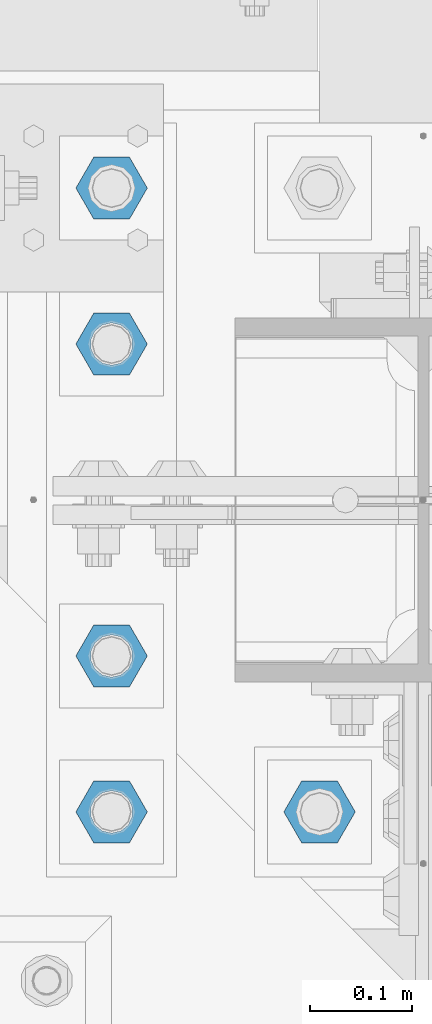
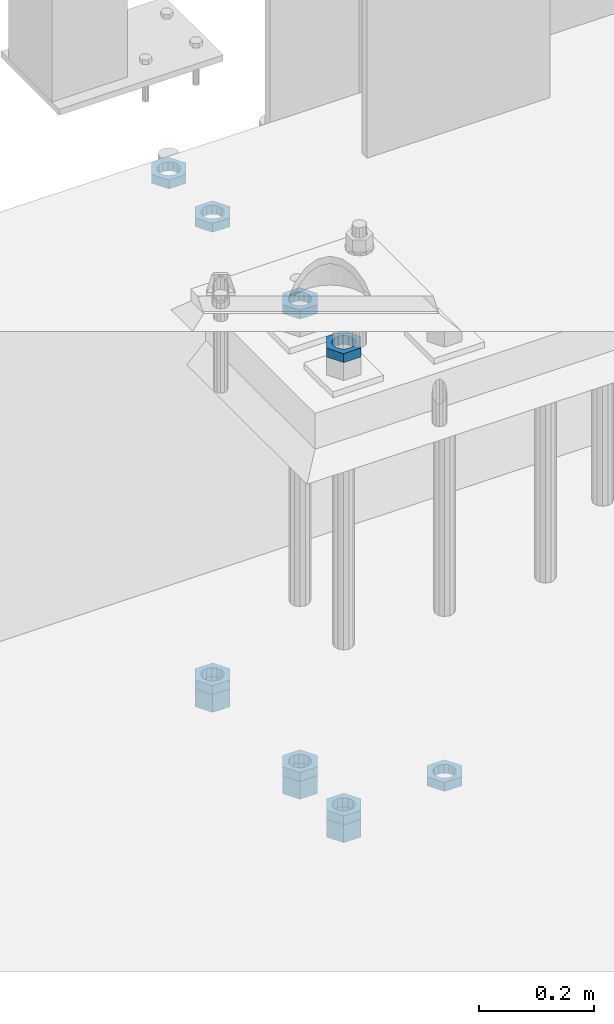
# One storey, part 2880 of 3843: 11 beams, 1 element without a shape of its own.
"""IFC2X3 building model written with IfcOpenShell, lengths in millimetres."""

from ifc_helpers import new_model, si_unit, frame, origin_with_axes, place, context, subcontext, project, spatial, faceted_brep, material, type_object, element, aggregate, save


model = new_model("IFC2X3")

# Units and contexts
model_context = context("Model", 3, precision=1e-05, world=origin_with_axes())
body_context = subcontext(model_context, "Body", "Model", "MODEL_VIEW")
ifc_project = project(units=[si_unit("LENGTHUNIT", "METRE", prefix="MILLI"), si_unit("AREAUNIT", "SQUARE_METRE"), si_unit("VOLUMEUNIT", "CUBIC_METRE"), si_unit("MASSUNIT", "GRAM", prefix="KILO"), si_unit("TIMEUNIT", "SECOND"), si_unit("PLANEANGLEUNIT", "RADIAN"), si_unit("SOLIDANGLEUNIT", "STERADIAN"), si_unit("THERMODYNAMICTEMPERATUREUNIT", "DEGREE_CELSIUS"), si_unit("LUMINOUSINTENSITYUNIT", "LUMEN")], contexts=[model_context])

# Site, building, storey
site_placement = place(None, origin_with_axes())
site = spatial("IfcSite", under=ifc_project, at=site_placement, CompositionType="ELEMENT")
building_placement = place(site_placement, origin_with_axes())
building = spatial("IfcBuilding", under=site, at=building_placement, Name="Undefined", CompositionType="ELEMENT")
storey_placement = place(building_placement, origin_with_axes())
storey = spatial("IfcBuildingStorey", under=building, at=storey_placement, Name="Undefined", CompositionType="ELEMENT", Elevation=0.0)

# Assembly, beams
assembly_placement = place(storey_placement, origin_with_axes())
assembly = element("IfcElementAssembly", 1, at=assembly_placement, inside=storey, Name="TEMPLATE", AssemblyPlace="NOTDEFINED", PredefinedType="RIGID_FRAME")
ifc_material = material(Name="STEEL/A572-50")
beam_type_1 = type_object("IfcBeamType", Name="1-1/2_HEAVY_HEX_NUT", PredefinedType="NOTDEFINED")
beam_1_placement = place(assembly_placement, frame((48691.8, 92367.1, 29203.6500015259), z_axis=(0.0, -1.0, 0.0), x_axis=(0.0, 0.0, -1.0)))
beam_1 = element("IfcBeam", 2, at=beam_1_placement, type_object=beam_type_1, material=ifc_material, Name="NUT", ObjectType="1-1/2_HEAVY_HEX_NUT", context=body_context, shape_type="Brep", body=[
    faceted_brep([(0.0, -34.9199981689453, 0.0), (0.0, -17.4599990844727, -30.25), (38.0999999999985, -17.4599990844727, -30.25), (38.0999999999985, -34.9199981689453, 0.0), (0.0, 17.4599990844727, -30.25), (38.0999999999985, 17.4599990844727, -30.25), (0.0, 34.9199981689453, 0.0), (38.0999999999985, 34.9199981689453, 0.0), (0.0, 17.4599990844727, 30.25), (38.0999999999985, 17.4599990844727, 30.25), (0.0, -17.4599990844727, 30.25), (38.0999999999985, -17.4599990844727, 30.25), (0.0, 0.0, 20.6399993896484), (0.0, 8.9553601105581, 18.5959968835959), (38.0999999999985, 8.9553601105581, 18.5959968835959), (38.0999999999985, 0.0, 20.6399993896484), (0.0, 16.1370013209525, 12.8688291298167), (38.0999999999985, 16.1370013209525, 12.8688291298167), (0.0, 20.1225115123816, 4.59283194104501), (38.0999999999985, 20.1225115123816, 4.59283194104501), (0.0, 20.1225115123816, -4.59283194104501), (38.0999999999985, 20.1225115123816, -4.59283194104501), (0.0, 16.1370013209525, -12.8688291298167), (38.0999999999985, 16.1370013209525, -12.8688291298167), (0.0, 8.9553601105581, -18.5959968835959), (38.0999999999985, 8.9553601105581, -18.5959968835959), (0.0, 0.0, -20.6399993896484), (38.0999999999985, 0.0, -20.6399993896484), (0.0, -8.9553601105581, -18.5959968835959), (38.0999999999985, -8.9553601105581, -18.5959968835959), (0.0, -16.1370013209525, -12.8688291298167), (38.0999999999985, -16.1370013209525, -12.8688291298167), (0.0, -20.1225115123816, -4.59283194104501), (38.0999999999985, -20.1225115123816, -4.59283194104501), (0.0, -20.1225115123816, 4.59283194104501), (38.0999999999985, -20.1225115123816, 4.59283194104501), (0.0, -16.1370013209525, 12.8688291298167), (38.0999999999985, -16.1370013209525, 12.8688291298167), (0.0, -8.9553601105581, 18.5959968835959), (38.0999999999985, -8.9553601105581, 18.5959968835959)], [[[0, 1, 2, 3]], [[1, 4, 5, 2]], [[4, 6, 7, 5]], [[6, 8, 9, 7]], [[8, 10, 11, 9]], [[10, 0, 3, 11]], [[12, 13, 14, 15]], [[13, 16, 17, 14]], [[16, 18, 19, 17]], [[18, 20, 21, 19]], [[20, 22, 23, 21]], [[22, 24, 25, 23]], [[24, 26, 27, 25]], [[26, 28, 29, 27]], [[28, 30, 31, 29]], [[30, 32, 33, 31]], [[32, 34, 35, 33]], [[34, 36, 37, 35]], [[36, 38, 39, 37]], [[38, 12, 15, 39]], [[5, 7, 9, 11, 3, 2], [17, 19, 21, 23, 25, 27, 29, 31, 33, 35, 37, 39, 15, 14]], [[10, 8, 6, 4, 1, 0], [38, 36, 34, 32, 30, 28, 26, 24, 22, 20, 18, 16, 13, 12]]]),
])
beam_2_placement = place(assembly_placement, frame((48691.8, 92062.3, 29203.6500015259), z_axis=(0.0, -1.0, 0.0), x_axis=(0.0, 0.0, -1.0)))
beam_2 = element("IfcBeam", 3, at=beam_2_placement, type_object=beam_type_1, material=ifc_material, Name="NUT", ObjectType="1-1/2_HEAVY_HEX_NUT", context=body_context, shape_type="Brep", body=[
    faceted_brep([(0.0, -34.9199981689453, 0.0), (0.0, -17.4599990844727, -30.25), (38.0999999999985, -17.4599990844727, -30.25), (38.0999999999985, -34.9199981689453, 0.0), (0.0, 17.4599990844727, -30.25), (38.0999999999985, 17.4599990844727, -30.25), (0.0, 34.9199981689453, 0.0), (38.0999999999985, 34.9199981689453, 0.0), (0.0, 17.4599990844727, 30.25), (38.0999999999985, 17.4599990844727, 30.25), (0.0, -17.4599990844727, 30.25), (38.0999999999985, -17.4599990844727, 30.25), (0.0, 0.0, 20.6399993896484), (0.0, 8.9553601105581, 18.5959968835959), (38.0999999999985, 8.9553601105581, 18.5959968835959), (38.0999999999985, 0.0, 20.6399993896484), (0.0, 16.1370013209525, 12.8688291298167), (38.0999999999985, 16.1370013209525, 12.8688291298167), (0.0, 20.1225115123816, 4.59283194104501), (38.0999999999985, 20.1225115123816, 4.59283194104501), (0.0, 20.1225115123816, -4.59283194104501), (38.0999999999985, 20.1225115123816, -4.59283194104501), (0.0, 16.1370013209525, -12.8688291298167), (38.0999999999985, 16.1370013209525, -12.8688291298167), (0.0, 8.9553601105581, -18.5959968835959), (38.0999999999985, 8.9553601105581, -18.5959968835959), (0.0, 0.0, -20.6399993896484), (38.0999999999985, 0.0, -20.6399993896484), (0.0, -8.9553601105581, -18.5959968835959), (38.0999999999985, -8.9553601105581, -18.5959968835959), (0.0, -16.1370013209525, -12.8688291298167), (38.0999999999985, -16.1370013209525, -12.8688291298167), (0.0, -20.1225115123816, -4.59283194104501), (38.0999999999985, -20.1225115123816, -4.59283194104501), (0.0, -20.1225115123816, 4.59283194104501), (38.0999999999985, -20.1225115123816, 4.59283194104501), (0.0, -16.1370013209525, 12.8688291298167), (38.0999999999985, -16.1370013209525, 12.8688291298167), (0.0, -8.9553601105581, 18.5959968835959), (38.0999999999985, -8.9553601105581, 18.5959968835959)], [[[0, 1, 2, 3]], [[1, 4, 5, 2]], [[4, 6, 7, 5]], [[6, 8, 9, 7]], [[8, 10, 11, 9]], [[10, 0, 3, 11]], [[12, 13, 14, 15]], [[13, 16, 17, 14]], [[16, 18, 19, 17]], [[18, 20, 21, 19]], [[20, 22, 23, 21]], [[22, 24, 25, 23]], [[24, 26, 27, 25]], [[26, 28, 29, 27]], [[28, 30, 31, 29]], [[30, 32, 33, 31]], [[32, 34, 35, 33]], [[34, 36, 37, 35]], [[36, 38, 39, 37]], [[38, 12, 15, 39]], [[5, 7, 9, 11, 3, 2], [17, 19, 21, 23, 25, 27, 29, 31, 33, 35, 37, 39, 15, 14]], [[10, 8, 6, 4, 1, 0], [38, 36, 34, 32, 30, 28, 26, 24, 22, 20, 18, 16, 13, 12]]]),
])
beam_3_placement = place(assembly_placement, frame((48691.8, 91909.9, 29203.6500015259), z_axis=(0.0, -1.0, 0.0), x_axis=(0.0, 0.0, -1.0)))
beam_3 = element("IfcBeam", 4, at=beam_3_placement, type_object=beam_type_1, material=ifc_material, Name="NUT", ObjectType="1-1/2_HEAVY_HEX_NUT", context=body_context, shape_type="Brep", body=[
    faceted_brep([(0.0, -34.9199981689453, 0.0), (0.0, -17.4599990844727, -30.25), (38.0999999999985, -17.4599990844727, -30.25), (38.0999999999985, -34.9199981689453, 0.0), (0.0, 17.4599990844727, -30.25), (38.0999999999985, 17.4599990844727, -30.25), (0.0, 34.9199981689453, 0.0), (38.0999999999985, 34.9199981689453, 0.0), (0.0, 17.4599990844727, 30.25), (38.0999999999985, 17.4599990844727, 30.25), (0.0, -17.4599990844727, 30.25), (38.0999999999985, -17.4599990844727, 30.25), (0.0, 0.0, 20.6399993896484), (0.0, 8.9553601105581, 18.5959968835959), (38.0999999999985, 8.9553601105581, 18.5959968835959), (38.0999999999985, 0.0, 20.6399993896484), (0.0, 16.1370013209525, 12.8688291298167), (38.0999999999985, 16.1370013209525, 12.8688291298167), (0.0, 20.1225115123816, 4.59283194104501), (38.0999999999985, 20.1225115123816, 4.59283194104501), (0.0, 20.1225115123816, -4.59283194104501), (38.0999999999985, 20.1225115123816, -4.59283194104501), (0.0, 16.1370013209525, -12.8688291298167), (38.0999999999985, 16.1370013209525, -12.8688291298167), (0.0, 8.9553601105581, -18.5959968835959), (38.0999999999985, 8.9553601105581, -18.5959968835959), (0.0, 0.0, -20.6399993896484), (38.0999999999985, 0.0, -20.6399993896484), (0.0, -8.9553601105581, -18.5959968835959), (38.0999999999985, -8.9553601105581, -18.5959968835959), (0.0, -16.1370013209525, -12.8688291298167), (38.0999999999985, -16.1370013209525, -12.8688291298167), (0.0, -20.1225115123816, -4.59283194104501), (38.0999999999985, -20.1225115123816, -4.59283194104501), (0.0, -20.1225115123816, 4.59283194104501), (38.0999999999985, -20.1225115123816, 4.59283194104501), (0.0, -16.1370013209525, 12.8688291298167), (38.0999999999985, -16.1370013209525, 12.8688291298167), (0.0, -8.9553601105581, 18.5959968835959), (38.0999999999985, -8.9553601105581, 18.5959968835959)], [[[0, 1, 2, 3]], [[1, 4, 5, 2]], [[4, 6, 7, 5]], [[6, 8, 9, 7]], [[8, 10, 11, 9]], [[10, 0, 3, 11]], [[12, 13, 14, 15]], [[13, 16, 17, 14]], [[16, 18, 19, 17]], [[18, 20, 21, 19]], [[20, 22, 23, 21]], [[22, 24, 25, 23]], [[24, 26, 27, 25]], [[26, 28, 29, 27]], [[28, 30, 31, 29]], [[30, 32, 33, 31]], [[32, 34, 35, 33]], [[34, 36, 37, 35]], [[36, 38, 39, 37]], [[38, 12, 15, 39]], [[5, 7, 9, 11, 3, 2], [17, 19, 21, 23, 25, 27, 29, 31, 33, 35, 37, 39, 15, 14]], [[10, 8, 6, 4, 1, 0], [38, 36, 34, 32, 30, 28, 26, 24, 22, 20, 18, 16, 13, 12]]]),
])
beam_type_2 = type_object("IfcBeamType", Name="1-1/2_HALF_NUT", PredefinedType="NOTDEFINED")
beam_4_placement = place(assembly_placement, frame((48691.8, 92519.5, 30206.95), z_axis=(0.0, -1.0, 0.0), x_axis=(0.0, 0.0, -1.0)))
beam_4 = element("IfcBeam", 5, at=beam_4_placement, type_object=beam_type_2, material=ifc_material, Name="NUT", ObjectType="1-1/2_HALF_NUT", context=body_context, shape_type="Brep", body=[
    faceted_brep([(0.0, -34.9199981689453, 0.0), (0.0, -17.4599990844727, -30.25), (19.0500000000029, -17.4599990844727, -30.25), (19.0500000000029, -34.9199981689453, 0.0), (0.0, 17.4599990844727, -30.25), (19.0500000000029, 17.4599990844727, -30.25), (0.0, 34.9199981689453, 0.0), (19.0500000000029, 34.9199981689453, 0.0), (0.0, 17.4599990844727, 30.25), (19.0500000000029, 17.4599990844727, 30.25), (0.0, -17.4599990844727, 30.25), (19.0500000000029, -17.4599990844727, 30.25), (0.0, 0.0, 20.6399993896484), (0.0, 8.9553601105581, 18.5959968835959), (19.0500000000029, 8.95536011056538, 18.5959968835959), (19.0500000000029, 0.0, 20.6399993896484), (0.0, 16.1370013209525, 12.8688291298167), (19.0500000000029, 16.1370013209489, 12.8688291298167), (0.0, 20.1225115123816, 4.59283194104501), (19.0500000000029, 20.1225115123852, 4.59283194104501), (0.0, 20.1225115123816, -4.59283194104501), (19.0500000000029, 20.1225115123852, -4.59283194104501), (0.0, 16.1370013209525, -12.8688291298167), (19.0500000000029, 16.1370013209489, -12.8688291298167), (0.0, 8.9553601105581, -18.5959968835959), (19.0500000000029, 8.95536011056538, -18.5959968835959), (0.0, 0.0, -20.6399993896484), (19.0500000000029, 0.0, -20.6399993896484), (0.0, -8.9553601105581, -18.5959968835959), (19.0500000000029, -8.95536011056538, -18.5959968835959), (0.0, -16.1370013209525, -12.8688291298167), (19.0500000000029, -16.1370013209489, -12.8688291298167), (0.0, -20.1225115123816, -4.59283194104501), (19.0500000000029, -20.1225115123852, -4.59283194104501), (0.0, -20.1225115123816, 4.59283194104501), (19.0500000000029, -20.1225115123852, 4.59283194104501), (0.0, -16.1370013209525, 12.8688291298167), (19.0500000000029, -16.1370013209489, 12.8688291298167), (0.0, -8.9553601105581, 18.5959968835959), (19.0500000000029, -8.95536011056538, 18.5959968835959)], [[[0, 1, 2, 3]], [[1, 4, 5, 2]], [[4, 6, 7, 5]], [[6, 8, 9, 7]], [[8, 10, 11, 9]], [[10, 0, 3, 11]], [[12, 13, 14, 15]], [[13, 16, 17, 14]], [[16, 18, 19, 17]], [[18, 20, 21, 19]], [[20, 22, 23, 21]], [[22, 24, 25, 23]], [[24, 26, 27, 25]], [[26, 28, 29, 27]], [[28, 30, 31, 29]], [[30, 32, 33, 31]], [[32, 34, 35, 33]], [[34, 36, 37, 35]], [[36, 38, 39, 37]], [[38, 12, 15, 39]], [[5, 7, 9, 11, 3, 2], [17, 19, 21, 23, 25, 27, 29, 31, 33, 35, 37, 39, 15, 14]], [[10, 8, 6, 4, 1, 0], [38, 36, 34, 32, 30, 28, 26, 24, 22, 20, 18, 16, 13, 12]]]),
])
beam_5_placement = place(assembly_placement, frame((48691.8, 92367.1, 29222.7000015259), z_axis=(0.0, -1.0, 0.0), x_axis=(0.0, 0.0, -1.0)))
beam_5 = element("IfcBeam", 6, at=beam_5_placement, type_object=beam_type_2, material=ifc_material, Name="NUT", ObjectType="1-1/2_HALF_NUT", context=body_context, shape_type="Brep", body=[
    faceted_brep([(0.0, -34.9199981689453, 0.0), (0.0, -17.4599990844727, -30.25), (19.0500000000029, -17.4599990844727, -30.25), (19.0500000000029, -34.9199981689453, 0.0), (0.0, 17.4599990844727, -30.25), (19.0500000000029, 17.4599990844727, -30.25), (0.0, 34.9199981689453, 0.0), (19.0500000000029, 34.9199981689453, 0.0), (0.0, 17.4599990844727, 30.25), (19.0500000000029, 17.4599990844727, 30.25), (0.0, -17.4599990844727, 30.25), (19.0500000000029, -17.4599990844727, 30.25), (0.0, 0.0, 20.6399993896484), (0.0, 8.9553601105581, 18.5959968835959), (19.0500000000029, 8.95536011056538, 18.5959968835959), (19.0500000000029, 0.0, 20.6399993896484), (0.0, 16.1370013209525, 12.8688291298167), (19.0500000000029, 16.1370013209489, 12.8688291298167), (0.0, 20.1225115123816, 4.59283194104501), (19.0500000000029, 20.1225115123852, 4.59283194104501), (0.0, 20.1225115123816, -4.59283194104501), (19.0500000000029, 20.1225115123852, -4.59283194104501), (0.0, 16.1370013209525, -12.8688291298167), (19.0500000000029, 16.1370013209489, -12.8688291298167), (0.0, 8.9553601105581, -18.5959968835959), (19.0500000000029, 8.95536011056538, -18.5959968835959), (0.0, 0.0, -20.6399993896484), (19.0500000000029, 0.0, -20.6399993896484), (0.0, -8.9553601105581, -18.5959968835959), (19.0500000000029, -8.95536011056538, -18.5959968835959), (0.0, -16.1370013209525, -12.8688291298167), (19.0500000000029, -16.1370013209489, -12.8688291298167), (0.0, -20.1225115123816, -4.59283194104501), (19.0500000000029, -20.1225115123852, -4.59283194104501), (0.0, -20.1225115123816, 4.59283194104501), (19.0500000000029, -20.1225115123852, 4.59283194104501), (0.0, -16.1370013209525, 12.8688291298167), (19.0500000000029, -16.1370013209489, 12.8688291298167), (0.0, -8.9553601105581, 18.5959968835959), (19.0500000000029, -8.95536011056538, 18.5959968835959)], [[[0, 1, 2, 3]], [[1, 4, 5, 2]], [[4, 6, 7, 5]], [[6, 8, 9, 7]], [[8, 10, 11, 9]], [[10, 0, 3, 11]], [[12, 13, 14, 15]], [[13, 16, 17, 14]], [[16, 18, 19, 17]], [[18, 20, 21, 19]], [[20, 22, 23, 21]], [[22, 24, 25, 23]], [[24, 26, 27, 25]], [[26, 28, 29, 27]], [[28, 30, 31, 29]], [[30, 32, 33, 31]], [[32, 34, 35, 33]], [[34, 36, 37, 35]], [[36, 38, 39, 37]], [[38, 12, 15, 39]], [[5, 7, 9, 11, 3, 2], [17, 19, 21, 23, 25, 27, 29, 31, 33, 35, 37, 39, 15, 14]], [[10, 8, 6, 4, 1, 0], [38, 36, 34, 32, 30, 28, 26, 24, 22, 20, 18, 16, 13, 12]]]),
])
beam_6_placement = place(assembly_placement, frame((48691.8, 92367.1, 30206.95), z_axis=(0.0, -1.0, 0.0), x_axis=(0.0, 0.0, -1.0)))
beam_6 = element("IfcBeam", 7, at=beam_6_placement, type_object=beam_type_2, material=ifc_material, Name="NUT", ObjectType="1-1/2_HALF_NUT", context=body_context, shape_type="Brep", body=[
    faceted_brep([(0.0, -34.9199981689453, 0.0), (0.0, -17.4599990844727, -30.25), (19.0500000000029, -17.4599990844727, -30.25), (19.0500000000029, -34.9199981689453, 0.0), (0.0, 17.4599990844727, -30.25), (19.0500000000029, 17.4599990844727, -30.25), (0.0, 34.9199981689453, 0.0), (19.0500000000029, 34.9199981689453, 0.0), (0.0, 17.4599990844727, 30.25), (19.0500000000029, 17.4599990844727, 30.25), (0.0, -17.4599990844727, 30.25), (19.0500000000029, -17.4599990844727, 30.25), (0.0, 0.0, 20.6399993896484), (0.0, 8.9553601105581, 18.5959968835959), (19.0500000000029, 8.95536011056538, 18.5959968835959), (19.0500000000029, 0.0, 20.6399993896484), (0.0, 16.1370013209525, 12.8688291298167), (19.0500000000029, 16.1370013209489, 12.8688291298167), (0.0, 20.1225115123816, 4.59283194104501), (19.0500000000029, 20.1225115123852, 4.59283194104501), (0.0, 20.1225115123816, -4.59283194104501), (19.0500000000029, 20.1225115123852, -4.59283194104501), (0.0, 16.1370013209525, -12.8688291298167), (19.0500000000029, 16.1370013209489, -12.8688291298167), (0.0, 8.9553601105581, -18.5959968835959), (19.0500000000029, 8.95536011056538, -18.5959968835959), (0.0, 0.0, -20.6399993896484), (19.0500000000029, 0.0, -20.6399993896484), (0.0, -8.9553601105581, -18.5959968835959), (19.0500000000029, -8.95536011056538, -18.5959968835959), (0.0, -16.1370013209525, -12.8688291298167), (19.0500000000029, -16.1370013209489, -12.8688291298167), (0.0, -20.1225115123816, -4.59283194104501), (19.0500000000029, -20.1225115123852, -4.59283194104501), (0.0, -20.1225115123816, 4.59283194104501), (19.0500000000029, -20.1225115123852, 4.59283194104501), (0.0, -16.1370013209525, 12.8688291298167), (19.0500000000029, -16.1370013209489, 12.8688291298167), (0.0, -8.9553601105581, 18.5959968835959), (19.0500000000029, -8.95536011056538, 18.5959968835959)], [[[0, 1, 2, 3]], [[1, 4, 5, 2]], [[4, 6, 7, 5]], [[6, 8, 9, 7]], [[8, 10, 11, 9]], [[10, 0, 3, 11]], [[12, 13, 14, 15]], [[13, 16, 17, 14]], [[16, 18, 19, 17]], [[18, 20, 21, 19]], [[20, 22, 23, 21]], [[22, 24, 25, 23]], [[24, 26, 27, 25]], [[26, 28, 29, 27]], [[28, 30, 31, 29]], [[30, 32, 33, 31]], [[32, 34, 35, 33]], [[34, 36, 37, 35]], [[36, 38, 39, 37]], [[38, 12, 15, 39]], [[5, 7, 9, 11, 3, 2], [17, 19, 21, 23, 25, 27, 29, 31, 33, 35, 37, 39, 15, 14]], [[10, 8, 6, 4, 1, 0], [38, 36, 34, 32, 30, 28, 26, 24, 22, 20, 18, 16, 13, 12]]]),
])
beam_7_placement = place(assembly_placement, frame((48691.8, 92062.3, 29222.7000015259), z_axis=(0.0, -1.0, 0.0), x_axis=(0.0, 0.0, -1.0)))
beam_7 = element("IfcBeam", 8, at=beam_7_placement, type_object=beam_type_2, material=ifc_material, Name="NUT", ObjectType="1-1/2_HALF_NUT", context=body_context, shape_type="Brep", body=[
    faceted_brep([(0.0, -34.9199981689453, 0.0), (0.0, -17.4599990844727, -30.25), (19.0500000000029, -17.4599990844727, -30.25), (19.0500000000029, -34.9199981689453, 0.0), (0.0, 17.4599990844727, -30.25), (19.0500000000029, 17.4599990844727, -30.25), (0.0, 34.9199981689453, 0.0), (19.0500000000029, 34.9199981689453, 0.0), (0.0, 17.4599990844727, 30.25), (19.0500000000029, 17.4599990844727, 30.25), (0.0, -17.4599990844727, 30.25), (19.0500000000029, -17.4599990844727, 30.25), (0.0, 0.0, 20.6399993896484), (0.0, 8.9553601105581, 18.5959968835959), (19.0500000000029, 8.95536011056538, 18.5959968835959), (19.0500000000029, 0.0, 20.6399993896484), (0.0, 16.1370013209525, 12.8688291298167), (19.0500000000029, 16.1370013209489, 12.8688291298167), (0.0, 20.1225115123816, 4.59283194104501), (19.0500000000029, 20.1225115123852, 4.59283194104501), (0.0, 20.1225115123816, -4.59283194104501), (19.0500000000029, 20.1225115123852, -4.59283194104501), (0.0, 16.1370013209525, -12.8688291298167), (19.0500000000029, 16.1370013209489, -12.8688291298167), (0.0, 8.9553601105581, -18.5959968835959), (19.0500000000029, 8.95536011056538, -18.5959968835959), (0.0, 0.0, -20.6399993896484), (19.0500000000029, 0.0, -20.6399993896484), (0.0, -8.9553601105581, -18.5959968835959), (19.0500000000029, -8.95536011056538, -18.5959968835959), (0.0, -16.1370013209525, -12.8688291298167), (19.0500000000029, -16.1370013209489, -12.8688291298167), (0.0, -20.1225115123816, -4.59283194104501), (19.0500000000029, -20.1225115123852, -4.59283194104501), (0.0, -20.1225115123816, 4.59283194104501), (19.0500000000029, -20.1225115123852, 4.59283194104501), (0.0, -16.1370013209525, 12.8688291298167), (19.0500000000029, -16.1370013209489, 12.8688291298167), (0.0, -8.9553601105581, 18.5959968835959), (19.0500000000029, -8.95536011056538, 18.5959968835959)], [[[0, 1, 2, 3]], [[1, 4, 5, 2]], [[4, 6, 7, 5]], [[6, 8, 9, 7]], [[8, 10, 11, 9]], [[10, 0, 3, 11]], [[12, 13, 14, 15]], [[13, 16, 17, 14]], [[16, 18, 19, 17]], [[18, 20, 21, 19]], [[20, 22, 23, 21]], [[22, 24, 25, 23]], [[24, 26, 27, 25]], [[26, 28, 29, 27]], [[28, 30, 31, 29]], [[30, 32, 33, 31]], [[32, 34, 35, 33]], [[34, 36, 37, 35]], [[36, 38, 39, 37]], [[38, 12, 15, 39]], [[5, 7, 9, 11, 3, 2], [17, 19, 21, 23, 25, 27, 29, 31, 33, 35, 37, 39, 15, 14]], [[10, 8, 6, 4, 1, 0], [38, 36, 34, 32, 30, 28, 26, 24, 22, 20, 18, 16, 13, 12]]]),
])
beam_8_placement = place(assembly_placement, frame((48691.8, 92062.3, 30206.95), z_axis=(0.0, -1.0, 0.0), x_axis=(0.0, 0.0, -1.0)))
beam_8 = element("IfcBeam", 9, at=beam_8_placement, type_object=beam_type_2, material=ifc_material, Name="NUT", ObjectType="1-1/2_HALF_NUT", context=body_context, shape_type="Brep", body=[
    faceted_brep([(0.0, -34.9199981689453, 0.0), (0.0, -17.4599990844727, -30.25), (19.0500000000029, -17.4599990844727, -30.25), (19.0500000000029, -34.9199981689453, 0.0), (0.0, 17.4599990844727, -30.25), (19.0500000000029, 17.4599990844727, -30.25), (0.0, 34.9199981689453, 0.0), (19.0500000000029, 34.9199981689453, 0.0), (0.0, 17.4599990844727, 30.25), (19.0500000000029, 17.4599990844727, 30.25), (0.0, -17.4599990844727, 30.25), (19.0500000000029, -17.4599990844727, 30.25), (0.0, 0.0, 20.6399993896484), (0.0, 8.9553601105581, 18.5959968835959), (19.0500000000029, 8.95536011056538, 18.5959968835959), (19.0500000000029, 0.0, 20.6399993896484), (0.0, 16.1370013209525, 12.8688291298167), (19.0500000000029, 16.1370013209489, 12.8688291298167), (0.0, 20.1225115123816, 4.59283194104501), (19.0500000000029, 20.1225115123852, 4.59283194104501), (0.0, 20.1225115123816, -4.59283194104501), (19.0500000000029, 20.1225115123852, -4.59283194104501), (0.0, 16.1370013209525, -12.8688291298167), (19.0500000000029, 16.1370013209489, -12.8688291298167), (0.0, 8.9553601105581, -18.5959968835959), (19.0500000000029, 8.95536011056538, -18.5959968835959), (0.0, 0.0, -20.6399993896484), (19.0500000000029, 0.0, -20.6399993896484), (0.0, -8.9553601105581, -18.5959968835959), (19.0500000000029, -8.95536011056538, -18.5959968835959), (0.0, -16.1370013209525, -12.8688291298167), (19.0500000000029, -16.1370013209489, -12.8688291298167), (0.0, -20.1225115123816, -4.59283194104501), (19.0500000000029, -20.1225115123852, -4.59283194104501), (0.0, -20.1225115123816, 4.59283194104501), (19.0500000000029, -20.1225115123852, 4.59283194104501), (0.0, -16.1370013209525, 12.8688291298167), (19.0500000000029, -16.1370013209489, 12.8688291298167), (0.0, -8.9553601105581, 18.5959968835959), (19.0500000000029, -8.95536011056538, 18.5959968835959)], [[[0, 1, 2, 3]], [[1, 4, 5, 2]], [[4, 6, 7, 5]], [[6, 8, 9, 7]], [[8, 10, 11, 9]], [[10, 0, 3, 11]], [[12, 13, 14, 15]], [[13, 16, 17, 14]], [[16, 18, 19, 17]], [[18, 20, 21, 19]], [[20, 22, 23, 21]], [[22, 24, 25, 23]], [[24, 26, 27, 25]], [[26, 28, 29, 27]], [[28, 30, 31, 29]], [[30, 32, 33, 31]], [[32, 34, 35, 33]], [[34, 36, 37, 35]], [[36, 38, 39, 37]], [[38, 12, 15, 39]], [[5, 7, 9, 11, 3, 2], [17, 19, 21, 23, 25, 27, 29, 31, 33, 35, 37, 39, 15, 14]], [[10, 8, 6, 4, 1, 0], [38, 36, 34, 32, 30, 28, 26, 24, 22, 20, 18, 16, 13, 12]]]),
])
beam_9_placement = place(assembly_placement, frame((48691.8, 91909.9, 29222.7000015259), z_axis=(0.0, -1.0, 0.0), x_axis=(0.0, 0.0, -1.0)))
beam_9 = element("IfcBeam", 10, at=beam_9_placement, type_object=beam_type_2, material=ifc_material, Name="NUT", ObjectType="1-1/2_HALF_NUT", context=body_context, shape_type="Brep", body=[
    faceted_brep([(0.0, -34.9199981689453, 0.0), (0.0, -17.4599990844727, -30.25), (19.0500000000029, -17.4599990844727, -30.25), (19.0500000000029, -34.9199981689453, 0.0), (0.0, 17.4599990844727, -30.25), (19.0500000000029, 17.4599990844727, -30.25), (0.0, 34.9199981689453, 0.0), (19.0500000000029, 34.9199981689453, 0.0), (0.0, 17.4599990844727, 30.25), (19.0500000000029, 17.4599990844727, 30.25), (0.0, -17.4599990844727, 30.25), (19.0500000000029, -17.4599990844727, 30.25), (0.0, 0.0, 20.6399993896484), (0.0, 8.9553601105581, 18.5959968835959), (19.0500000000029, 8.95536011056538, 18.5959968835959), (19.0500000000029, 0.0, 20.6399993896484), (0.0, 16.1370013209525, 12.8688291298167), (19.0500000000029, 16.1370013209489, 12.8688291298167), (0.0, 20.1225115123816, 4.59283194104501), (19.0500000000029, 20.1225115123852, 4.59283194104501), (0.0, 20.1225115123816, -4.59283194104501), (19.0500000000029, 20.1225115123852, -4.59283194104501), (0.0, 16.1370013209525, -12.8688291298167), (19.0500000000029, 16.1370013209489, -12.8688291298167), (0.0, 8.9553601105581, -18.5959968835959), (19.0500000000029, 8.95536011056538, -18.5959968835959), (0.0, 0.0, -20.6399993896484), (19.0500000000029, 0.0, -20.6399993896484), (0.0, -8.9553601105581, -18.5959968835959), (19.0500000000029, -8.95536011056538, -18.5959968835959), (0.0, -16.1370013209525, -12.8688291298167), (19.0500000000029, -16.1370013209489, -12.8688291298167), (0.0, -20.1225115123816, -4.59283194104501), (19.0500000000029, -20.1225115123852, -4.59283194104501), (0.0, -20.1225115123816, 4.59283194104501), (19.0500000000029, -20.1225115123852, 4.59283194104501), (0.0, -16.1370013209525, 12.8688291298167), (19.0500000000029, -16.1370013209489, 12.8688291298167), (0.0, -8.9553601105581, 18.5959968835959), (19.0500000000029, -8.95536011056538, 18.5959968835959)], [[[0, 1, 2, 3]], [[1, 4, 5, 2]], [[4, 6, 7, 5]], [[6, 8, 9, 7]], [[8, 10, 11, 9]], [[10, 0, 3, 11]], [[12, 13, 14, 15]], [[13, 16, 17, 14]], [[16, 18, 19, 17]], [[18, 20, 21, 19]], [[20, 22, 23, 21]], [[22, 24, 25, 23]], [[24, 26, 27, 25]], [[26, 28, 29, 27]], [[28, 30, 31, 29]], [[30, 32, 33, 31]], [[32, 34, 35, 33]], [[34, 36, 37, 35]], [[36, 38, 39, 37]], [[38, 12, 15, 39]], [[5, 7, 9, 11, 3, 2], [17, 19, 21, 23, 25, 27, 29, 31, 33, 35, 37, 39, 15, 14]], [[10, 8, 6, 4, 1, 0], [38, 36, 34, 32, 30, 28, 26, 24, 22, 20, 18, 16, 13, 12]]]),
])
beam_10_placement = place(assembly_placement, frame((48691.8, 91909.9, 30206.95), z_axis=(0.0, -1.0, 0.0), x_axis=(0.0, 0.0, -1.0)))
beam_10 = element("IfcBeam", 11, at=beam_10_placement, type_object=beam_type_2, material=ifc_material, Name="NUT", ObjectType="1-1/2_HALF_NUT", context=body_context, shape_type="Brep", body=[
    faceted_brep([(0.0, -34.9199981689453, 0.0), (0.0, -17.4599990844727, -30.25), (19.0500000000029, -17.4599990844727, -30.25), (19.0500000000029, -34.9199981689453, 0.0), (0.0, 17.4599990844727, -30.25), (19.0500000000029, 17.4599990844727, -30.25), (0.0, 34.9199981689453, 0.0), (19.0500000000029, 34.9199981689453, 0.0), (0.0, 17.4599990844727, 30.25), (19.0500000000029, 17.4599990844727, 30.25), (0.0, -17.4599990844727, 30.25), (19.0500000000029, -17.4599990844727, 30.25), (0.0, 0.0, 20.6399993896484), (0.0, 8.9553601105581, 18.5959968835959), (19.0500000000029, 8.95536011056538, 18.5959968835959), (19.0500000000029, 0.0, 20.6399993896484), (0.0, 16.1370013209525, 12.8688291298167), (19.0500000000029, 16.1370013209489, 12.8688291298167), (0.0, 20.1225115123816, 4.59283194104501), (19.0500000000029, 20.1225115123852, 4.59283194104501), (0.0, 20.1225115123816, -4.59283194104501), (19.0500000000029, 20.1225115123852, -4.59283194104501), (0.0, 16.1370013209525, -12.8688291298167), (19.0500000000029, 16.1370013209489, -12.8688291298167), (0.0, 8.9553601105581, -18.5959968835959), (19.0500000000029, 8.95536011056538, -18.5959968835959), (0.0, 0.0, -20.6399993896484), (19.0500000000029, 0.0, -20.6399993896484), (0.0, -8.9553601105581, -18.5959968835959), (19.0500000000029, -8.95536011056538, -18.5959968835959), (0.0, -16.1370013209525, -12.8688291298167), (19.0500000000029, -16.1370013209489, -12.8688291298167), (0.0, -20.1225115123816, -4.59283194104501), (19.0500000000029, -20.1225115123852, -4.59283194104501), (0.0, -20.1225115123816, 4.59283194104501), (19.0500000000029, -20.1225115123852, 4.59283194104501), (0.0, -16.1370013209525, 12.8688291298167), (19.0500000000029, -16.1370013209489, 12.8688291298167), (0.0, -8.9553601105581, 18.5959968835959), (19.0500000000029, -8.95536011056538, 18.5959968835959)], [[[0, 1, 2, 3]], [[1, 4, 5, 2]], [[4, 6, 7, 5]], [[6, 8, 9, 7]], [[8, 10, 11, 9]], [[10, 0, 3, 11]], [[12, 13, 14, 15]], [[13, 16, 17, 14]], [[16, 18, 19, 17]], [[18, 20, 21, 19]], [[20, 22, 23, 21]], [[22, 24, 25, 23]], [[24, 26, 27, 25]], [[26, 28, 29, 27]], [[28, 30, 31, 29]], [[30, 32, 33, 31]], [[32, 34, 35, 33]], [[34, 36, 37, 35]], [[36, 38, 39, 37]], [[38, 12, 15, 39]], [[5, 7, 9, 11, 3, 2], [17, 19, 21, 23, 25, 27, 29, 31, 33, 35, 37, 39, 15, 14]], [[10, 8, 6, 4, 1, 0], [38, 36, 34, 32, 30, 28, 26, 24, 22, 20, 18, 16, 13, 12]]]),
])
beam_11_placement = place(assembly_placement, frame((48895.0, 91909.9, 29222.7000015259), z_axis=(0.0, -1.0, 0.0), x_axis=(0.0, 0.0, -1.0)))
beam_11 = element("IfcBeam", 12, at=beam_11_placement, type_object=beam_type_2, material=ifc_material, Name="NUT", ObjectType="1-1/2_HALF_NUT", context=body_context, shape_type="Brep", body=[
    faceted_brep([(0.0, -34.9199981689453, 0.0), (0.0, -17.4599990844727, -30.25), (19.0500000000029, -17.4599990844727, -30.25), (19.0500000000029, -34.9199981689453, 0.0), (0.0, 17.4599990844727, -30.25), (19.0500000000029, 17.4599990844727, -30.25), (0.0, 34.9199981689453, 0.0), (19.0500000000029, 34.9199981689453, 0.0), (0.0, 17.4599990844727, 30.25), (19.0500000000029, 17.4599990844727, 30.25), (0.0, -17.4599990844727, 30.25), (19.0500000000029, -17.4599990844727, 30.25), (0.0, 0.0, 20.6399993896484), (0.0, 8.9553601105581, 18.5959968835959), (19.0500000000029, 8.95536011056538, 18.5959968835959), (19.0500000000029, 0.0, 20.6399993896484), (0.0, 16.1370013209525, 12.8688291298167), (19.0500000000029, 16.1370013209489, 12.8688291298167), (0.0, 20.1225115123816, 4.59283194104501), (19.0500000000029, 20.1225115123852, 4.59283194104501), (0.0, 20.1225115123816, -4.59283194104501), (19.0500000000029, 20.1225115123852, -4.59283194104501), (0.0, 16.1370013209525, -12.8688291298167), (19.0500000000029, 16.1370013209489, -12.8688291298167), (0.0, 8.9553601105581, -18.5959968835959), (19.0500000000029, 8.95536011056538, -18.5959968835959), (0.0, 0.0, -20.6399993896484), (19.0500000000029, 0.0, -20.6399993896484), (0.0, -8.9553601105581, -18.5959968835959), (19.0500000000029, -8.95536011056538, -18.5959968835959), (0.0, -16.1370013209525, -12.8688291298167), (19.0500000000029, -16.1370013209489, -12.8688291298167), (0.0, -20.1225115123816, -4.59283194104501), (19.0500000000029, -20.1225115123852, -4.59283194104501), (0.0, -20.1225115123816, 4.59283194104501), (19.0500000000029, -20.1225115123852, 4.59283194104501), (0.0, -16.1370013209525, 12.8688291298167), (19.0500000000029, -16.1370013209489, 12.8688291298167), (0.0, -8.9553601105581, 18.5959968835959), (19.0500000000029, -8.95536011056538, 18.5959968835959)], [[[0, 1, 2, 3]], [[1, 4, 5, 2]], [[4, 6, 7, 5]], [[6, 8, 9, 7]], [[8, 10, 11, 9]], [[10, 0, 3, 11]], [[12, 13, 14, 15]], [[13, 16, 17, 14]], [[16, 18, 19, 17]], [[18, 20, 21, 19]], [[20, 22, 23, 21]], [[22, 24, 25, 23]], [[24, 26, 27, 25]], [[26, 28, 29, 27]], [[28, 30, 31, 29]], [[30, 32, 33, 31]], [[32, 34, 35, 33]], [[34, 36, 37, 35]], [[36, 38, 39, 37]], [[38, 12, 15, 39]], [[5, 7, 9, 11, 3, 2], [17, 19, 21, 23, 25, 27, 29, 31, 33, 35, 37, 39, 15, 14]], [[10, 8, 6, 4, 1, 0], [38, 36, 34, 32, 30, 28, 26, 24, 22, 20, 18, 16, 13, 12]]]),
])
aggregate(assembly, [beam_4, beam_5, beam_1, beam_6, beam_7, beam_2, beam_8, beam_9, beam_3, beam_10, beam_11])

save(model, "model.ifc")
